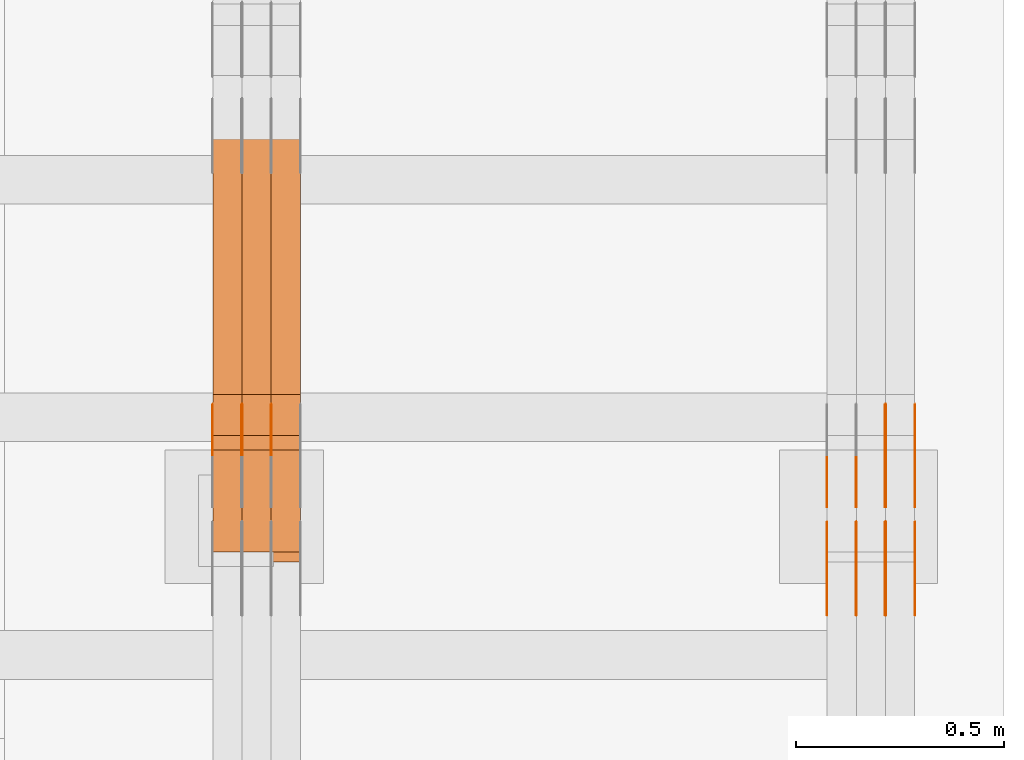
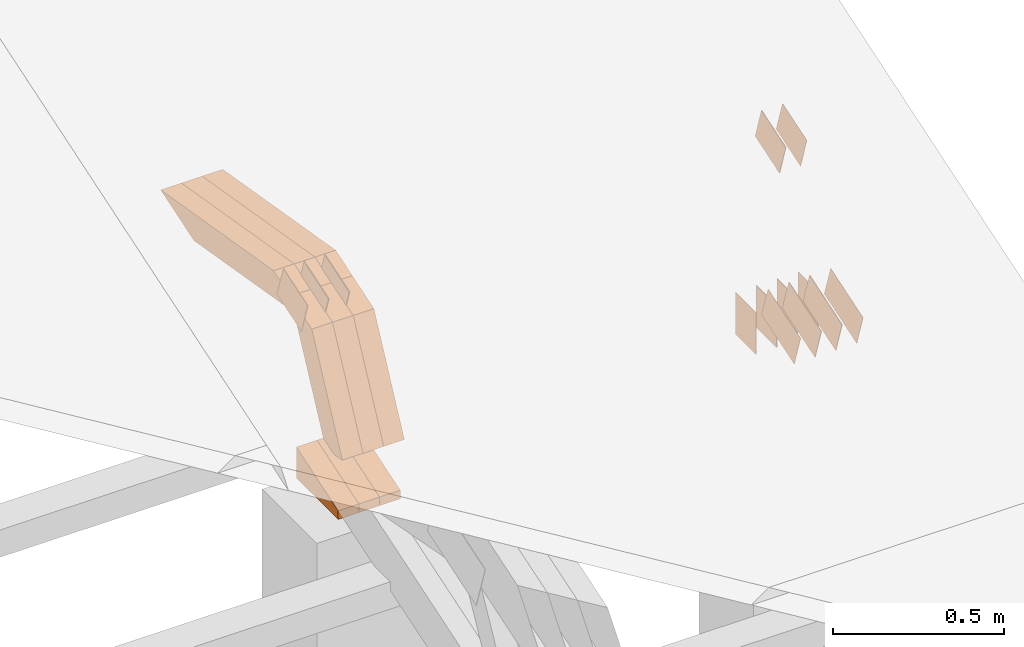
# One storey, part 321 of 385: 29 proxies.
"""IFC2X3 building model written with IfcOpenShell, lengths in millimetres."""

from ifc_helpers import new_model, entity, si_unit, converted_unit, derived_unit, direction, frame, frame_2d, origin, place, context, subcontext, project, spatial, polyline, rectangle, outline, extrude, source, transform, mapped, material, type_object, type_shapes, element, save


model = new_model("IFC2X3")

# Units and contexts
model_context = context("Model", 3, precision=0.01, world=origin(), true_north=direction((6.12303176911189e-17, 1.0)))
body_context = subcontext(model_context, "Body", "Model", "MODEL_VIEW")
ifc_project = project(units=[si_unit("LENGTHUNIT", "METRE", prefix="MILLI"), si_unit("AREAUNIT", "SQUARE_METRE"), si_unit("VOLUMEUNIT", "CUBIC_METRE"), converted_unit("PLANEANGLEUNIT", "DEGREE", entity("IfcRatioMeasure", 0.0174532925199433), si_unit("PLANEANGLEUNIT", "RADIAN"), dimensions=[0, 0, 0, 0, 0, 0, 0]), si_unit("MASSUNIT", "GRAM", prefix="KILO"), derived_unit("MASSDENSITYUNIT", [(si_unit("MASSUNIT", "GRAM", prefix="KILO"), 1), (si_unit("LENGTHUNIT", "METRE"), -3)]), si_unit("TIMEUNIT", "SECOND"), si_unit("FREQUENCYUNIT", "HERTZ"), si_unit("THERMODYNAMICTEMPERATUREUNIT", "DEGREE_CELSIUS"), derived_unit("THERMALTRANSMITTANCEUNIT", [(si_unit("MASSUNIT", "GRAM", prefix="KILO"), 1), (si_unit("THERMODYNAMICTEMPERATUREUNIT", "KELVIN"), -1), (si_unit("TIMEUNIT", "SECOND"), -3)]), derived_unit("VOLUMETRICFLOWRATEUNIT", [(si_unit("LENGTHUNIT", "METRE"), 3), (si_unit("TIMEUNIT", "SECOND"), -1)]), si_unit("ELECTRICCURRENTUNIT", "AMPERE"), si_unit("ELECTRICVOLTAGEUNIT", "VOLT"), si_unit("POWERUNIT", "WATT"), si_unit("FORCEUNIT", "NEWTON", prefix="KILO"), si_unit("ILLUMINANCEUNIT", "LUX"), si_unit("LUMINOUSFLUXUNIT", "LUMEN"), si_unit("LUMINOUSINTENSITYUNIT", "CANDELA"), derived_unit("USERDEFINED", [(si_unit("MASSUNIT", "GRAM", prefix="KILO"), -1), (si_unit("LENGTHUNIT", "METRE"), -2), (si_unit("TIMEUNIT", "SECOND"), 3), (si_unit("LUMINOUSFLUXUNIT", "LUMEN"), 1)]), derived_unit("LINEARVELOCITYUNIT", [(si_unit("LENGTHUNIT", "METRE"), 1), (si_unit("TIMEUNIT", "SECOND"), -1)]), si_unit("PRESSUREUNIT", "PASCAL"), derived_unit("USERDEFINED", [(si_unit("LENGTHUNIT", "METRE"), -2), (si_unit("MASSUNIT", "GRAM", prefix="KILO"), 1), (si_unit("TIMEUNIT", "SECOND"), -2)])], contexts=[model_context])

# Site, building, storey
site_placement = place(None, origin())
site = spatial("IfcSite", under=ifc_project, at=site_placement, CompositionType="ELEMENT")
building_placement = place(site_placement, origin())
building = spatial("IfcBuilding", under=site, at=building_placement, CompositionType="ELEMENT")
storey_placement = place(building_placement, origin())
storey = spatial("IfcBuildingStorey", under=building, at=storey_placement, Name="Default", CompositionType="ELEMENT", Elevation=0.0)

# Proxies
ifc_material_1 = material(Name="IfcSurfaceStyle #620272")
building_element_proxy_type_1 = type_object("IfcBuildingElementProxyType", PredefinedType="NOTDEFINED", material=ifc_material_1)
shared_shape_1 = source(origin(), body_context, "Body", "SweptSolid", [
    extrude(outline(polyline([(-99.9997874178038, -60.0000528641967), (99.9998102700997, -60.0000528641967), (99.9998251396068, 60.0000528641967), (-99.9998479919027, 60.0000528641967), (-99.9997874178038, -60.0000528641967)])), frame((99.9999918898597, 60.0000528641967, 0.0), z_axis=(0.0, 0.0, 1.0), x_axis=(-1.0, 0.0, 0.0)), (0.0, 0.0, 1.0), 1.3),
])
type_shapes(building_element_proxy_type_1, [shared_shape_1])
proxy_1_placement = place(building_placement, frame((49861.3, 11991.9568177725, 3072.52282247925), z_axis=(-1.0, 0.0, 0.0), x_axis=(0.0, 0.951056516295124, 0.309016994375039)))
element("IfcBuildingElementProxy", 1, at=proxy_1_placement, inside=storey, type_object=building_element_proxy_type_1, material=ifc_material_1, context=body_context, shape_type="MappedRepresentation", body=[
    mapped(shared_shape_1, transform((0.0, 0.0, 0.0), scale=1.0)),
])
ifc_material_2 = material(Name="IfcSurfaceStyle #620215")
building_element_proxy_type_2 = type_object("IfcBuildingElementProxyType", PredefinedType="NOTDEFINED", material=ifc_material_2)
shared_shape_2 = source(origin(), body_context, "Body", "SweptSolid", [
    extrude(outline(polyline([(-99.9997874178038, -60.0000528641967), (99.9998102700997, -60.0000528641967), (99.9998251396068, 60.0000528641967), (-99.9998479919027, 60.0000528641967), (-99.9997874178038, -60.0000528641967)])), frame((99.9999918898597, 60.0000528641967, 0.0), z_axis=(0.0, 0.0, 1.0), x_axis=(-1.0, 0.0, 0.0)), (0.0, 0.0, 1.0), 1.3),
])
type_shapes(building_element_proxy_type_2, [shared_shape_2])
proxy_2_placement = place(building_placement, frame((49790.0, 11991.9568177725, 3072.52282247925), z_axis=(-1.0, 0.0, 0.0), x_axis=(0.0, 0.951056516295124, 0.309016994375039)))
element("IfcBuildingElementProxy", 2, at=proxy_2_placement, inside=storey, type_object=building_element_proxy_type_2, material=ifc_material_2, context=body_context, shape_type="MappedRepresentation", body=[
    mapped(shared_shape_2, transform((0.0, 0.0, 0.0), scale=1.0)),
])
ifc_material_3 = material(Name="IfcSurfaceStyle #620158")
building_element_proxy_type_3 = type_object("IfcBuildingElementProxyType", PredefinedType="NOTDEFINED", material=ifc_material_3)
shared_shape_3 = source(origin(), body_context, "Body", "SweptSolid", [
    extrude(outline(polyline([(-99.9997874178038, -60.0000528641967), (99.9998102700997, -60.0000528641967), (99.9998251396068, 60.0000528641967), (-99.9998479919027, 60.0000528641967), (-99.9997874178038, -60.0000528641967)])), frame((99.9999918898597, 60.0000528641967, 0.0), z_axis=(0.0, 0.0, 1.0), x_axis=(-1.0, 0.0, 0.0)), (0.0, 0.0, 1.0), 1.3),
])
type_shapes(building_element_proxy_type_3, [shared_shape_3])
proxy_3_placement = place(building_placement, frame((49791.3, 11991.9568177725, 3072.52282247925), z_axis=(-1.0, 0.0, 0.0), x_axis=(0.0, 0.951056516295124, 0.309016994375039)))
element("IfcBuildingElementProxy", 3, at=proxy_3_placement, inside=storey, type_object=building_element_proxy_type_3, material=ifc_material_3, context=body_context, shape_type="MappedRepresentation", body=[
    mapped(shared_shape_3, transform((0.0, 0.0, 0.0), scale=1.0)),
])
ifc_material_4 = material(Name="IfcSurfaceStyle #620101")
building_element_proxy_type_4 = type_object("IfcBuildingElementProxyType", PredefinedType="NOTDEFINED", material=ifc_material_4)
shared_shape_4 = source(origin(), body_context, "Body", "SweptSolid", [
    extrude(outline(polyline([(-99.9997874178038, -60.0000528641967), (99.9998102700997, -60.0000528641967), (99.9998251396068, 60.0000528641967), (-99.9998479919027, 60.0000528641967), (-99.9997874178038, -60.0000528641967)])), frame((99.9999918898597, 60.0000528641967, 0.0), z_axis=(0.0, 0.0, 1.0), x_axis=(-1.0, 0.0, 0.0)), (0.0, 0.0, 1.0), 1.29999999999998),
])
type_shapes(building_element_proxy_type_4, [shared_shape_4])
proxy_4_placement = place(building_placement, frame((49720.0, 11991.9568177725, 3072.52282247925), z_axis=(-1.0, 0.0, 0.0), x_axis=(0.0, 0.951056516295124, 0.309016994375039)))
element("IfcBuildingElementProxy", 4, at=proxy_4_placement, inside=storey, type_object=building_element_proxy_type_4, material=ifc_material_4, context=body_context, shape_type="MappedRepresentation", body=[
    mapped(shared_shape_4, transform((0.0, 0.0, 0.0), scale=1.0)),
])
ifc_material_5 = material(Name="IfcSurfaceStyle #620044")
building_element_proxy_type_5 = type_object("IfcBuildingElementProxyType", PredefinedType="NOTDEFINED", material=ifc_material_5)
shared_shape_5 = source(origin(), body_context, "Body", "SweptSolid", [
    extrude(outline(polyline([(-99.9997874178038, -60.0000528641967), (99.9998102700997, -60.0000528641967), (99.9998251396068, 60.0000528641967), (-99.9998479919027, 60.0000528641967), (-99.9997874178038, -60.0000528641967)])), frame((99.9999918898597, 60.0000528641967, 0.0), z_axis=(0.0, 0.0, 1.0), x_axis=(-1.0, 0.0, 0.0)), (0.0, 0.0, 1.0), 1.29999999999998),
])
type_shapes(building_element_proxy_type_5, [shared_shape_5])
proxy_5_placement = place(building_placement, frame((49721.3, 11991.9568177725, 3072.52282247925), z_axis=(-1.0, 0.0, 0.0), x_axis=(0.0, 0.951056516295124, 0.309016994375039)))
element("IfcBuildingElementProxy", 5, at=proxy_5_placement, inside=storey, type_object=building_element_proxy_type_5, material=ifc_material_5, context=body_context, shape_type="MappedRepresentation", body=[
    mapped(shared_shape_5, transform((0.0, 0.0, 0.0), scale=1.0)),
])
ifc_material_6 = material(Name="IfcSurfaceStyle #619987")
building_element_proxy_type_6 = type_object("IfcBuildingElementProxyType", PredefinedType="NOTDEFINED", material=ifc_material_6)
shared_shape_6 = source(origin(), body_context, "Body", "SweptSolid", [
    extrude(outline(polyline([(-99.9997874178038, -60.0000528641967), (99.9998102700997, -60.0000528641967), (99.9998251396068, 60.0000528641967), (-99.9998479919027, 60.0000528641967), (-99.9997874178038, -60.0000528641967)])), frame((99.9999918898597, 60.0000528641967, 0.0), z_axis=(0.0, 0.0, 1.0), x_axis=(-1.0, 0.0, 0.0)), (0.0, 0.0, 1.0), 1.29999999999999),
])
type_shapes(building_element_proxy_type_6, [shared_shape_6])
proxy_6_placement = place(building_placement, frame((49650.0, 11991.9568177725, 3072.52282247925), z_axis=(-1.0, 0.0, 0.0), x_axis=(0.0, 0.951056516295124, 0.309016994375039)))
element("IfcBuildingElementProxy", 6, at=proxy_6_placement, inside=storey, type_object=building_element_proxy_type_6, material=ifc_material_6, context=body_context, shape_type="MappedRepresentation", body=[
    mapped(shared_shape_6, transform((0.0, 0.0, 0.0), scale=1.0)),
])
ifc_material_7 = material(Name="IfcSurfaceStyle #619930")
building_element_proxy_type_7 = type_object("IfcBuildingElementProxyType", PredefinedType="NOTDEFINED", material=ifc_material_7)
shared_shape_7 = source(origin(), body_context, "Body", "SweptSolid", [
    extrude(rectangle(XDim=150.0, YDim=119.999999999985, at=frame_2d((-7.105427357601e-15, 0.0), x_axis=(1.0, 0.0))), frame((75.0, 60.0, 0.0), z_axis=(0.0, 0.0, 1.0), x_axis=(-1.0, 0.0, 0.0)), (0.0, 0.0, 1.0), 1.3),
])
type_shapes(building_element_proxy_type_7, [shared_shape_7])
proxy_7_placement = place(building_placement, frame((49861.3, 12372.95703125, 3007.04687500001), z_axis=(-1.0, 0.0, 0.0), x_axis=(0.0, 0.0, -1.0)))
element("IfcBuildingElementProxy", 7, at=proxy_7_placement, inside=storey, type_object=building_element_proxy_type_7, material=ifc_material_7, context=body_context, shape_type="MappedRepresentation", body=[
    mapped(shared_shape_7, transform((0.0, 0.0, 0.0), scale=1.0)),
])
ifc_material_8 = material(Name="IfcSurfaceStyle #619873")
building_element_proxy_type_8 = type_object("IfcBuildingElementProxyType", PredefinedType="NOTDEFINED", material=ifc_material_8)
shared_shape_8 = source(origin(), body_context, "Body", "SweptSolid", [
    extrude(rectangle(XDim=150.0, YDim=119.999999999985, at=frame_2d((-7.105427357601e-15, 0.0), x_axis=(1.0, 0.0))), frame((75.0, 60.0, 0.0), z_axis=(0.0, 0.0, 1.0), x_axis=(-1.0, 0.0, 0.0)), (0.0, 0.0, 1.0), 1.3),
])
type_shapes(building_element_proxy_type_8, [shared_shape_8])
proxy_8_placement = place(building_placement, frame((49790.0, 12372.95703125, 3007.04687500001), z_axis=(-1.0, 0.0, 0.0), x_axis=(0.0, 0.0, -1.0)))
element("IfcBuildingElementProxy", 8, at=proxy_8_placement, inside=storey, type_object=building_element_proxy_type_8, material=ifc_material_8, context=body_context, shape_type="MappedRepresentation", body=[
    mapped(shared_shape_8, transform((0.0, 0.0, 0.0), scale=1.0)),
])
ifc_material_9 = material(Name="IfcSurfaceStyle #619816")
building_element_proxy_type_9 = type_object("IfcBuildingElementProxyType", PredefinedType="NOTDEFINED", material=ifc_material_9)
shared_shape_9 = source(origin(), body_context, "Body", "SweptSolid", [
    extrude(rectangle(XDim=150.0, YDim=119.999999999985, at=frame_2d((-7.105427357601e-15, 0.0), x_axis=(1.0, 0.0))), frame((75.0, 60.0, 0.0), z_axis=(0.0, 0.0, 1.0), x_axis=(-1.0, 0.0, 0.0)), (0.0, 0.0, 1.0), 1.3),
])
type_shapes(building_element_proxy_type_9, [shared_shape_9])
proxy_9_placement = place(building_placement, frame((49791.3, 12372.95703125, 3007.04687500001), z_axis=(-1.0, 0.0, 0.0), x_axis=(0.0, 0.0, -1.0)))
element("IfcBuildingElementProxy", 9, at=proxy_9_placement, inside=storey, type_object=building_element_proxy_type_9, material=ifc_material_9, context=body_context, shape_type="MappedRepresentation", body=[
    mapped(shared_shape_9, transform((0.0, 0.0, 0.0), scale=1.0)),
])
ifc_material_10 = material(Name="IfcSurfaceStyle #619759")
building_element_proxy_type_10 = type_object("IfcBuildingElementProxyType", PredefinedType="NOTDEFINED", material=ifc_material_10)
shared_shape_10 = source(origin(), body_context, "Body", "SweptSolid", [
    extrude(rectangle(XDim=150.0, YDim=119.999999999985, at=frame_2d((-7.105427357601e-15, 0.0), x_axis=(1.0, 0.0))), frame((75.0, 60.0, 0.0), z_axis=(0.0, 0.0, 1.0), x_axis=(-1.0, 0.0, 0.0)), (0.0, 0.0, 1.0), 1.29999999999999),
])
type_shapes(building_element_proxy_type_10, [shared_shape_10])
proxy_10_placement = place(building_placement, frame((49720.0, 12372.95703125, 3007.04687500001), z_axis=(-1.0, 0.0, 0.0), x_axis=(0.0, 0.0, -1.0)))
element("IfcBuildingElementProxy", 10, at=proxy_10_placement, inside=storey, type_object=building_element_proxy_type_10, material=ifc_material_10, context=body_context, shape_type="MappedRepresentation", body=[
    mapped(shared_shape_10, transform((0.0, 0.0, 0.0), scale=1.0)),
])
ifc_material_11 = material(Name="IfcSurfaceStyle #619702")
building_element_proxy_type_11 = type_object("IfcBuildingElementProxyType", PredefinedType="NOTDEFINED", material=ifc_material_11)
shared_shape_11 = source(origin(), body_context, "Body", "SweptSolid", [
    extrude(rectangle(XDim=150.0, YDim=119.999999999985, at=frame_2d((-7.105427357601e-15, 0.0), x_axis=(1.0, 0.0))), frame((75.0, 60.0, 0.0), z_axis=(0.0, 0.0, 1.0), x_axis=(-1.0, 0.0, 0.0)), (0.0, 0.0, 1.0), 1.29999999999999),
])
type_shapes(building_element_proxy_type_11, [shared_shape_11])
proxy_11_placement = place(building_placement, frame((49721.3, 12372.95703125, 3007.04687500001), z_axis=(-1.0, 0.0, 0.0), x_axis=(0.0, 0.0, -1.0)))
element("IfcBuildingElementProxy", 11, at=proxy_11_placement, inside=storey, type_object=building_element_proxy_type_11, material=ifc_material_11, context=body_context, shape_type="MappedRepresentation", body=[
    mapped(shared_shape_11, transform((0.0, 0.0, 0.0), scale=1.0)),
])
ifc_material_12 = material(Name="IfcSurfaceStyle #619645")
building_element_proxy_type_12 = type_object("IfcBuildingElementProxyType", PredefinedType="NOTDEFINED", material=ifc_material_12)
shared_shape_12 = source(origin(), body_context, "Body", "SweptSolid", [
    extrude(rectangle(XDim=150.0, YDim=119.999999999985, at=frame_2d((-7.105427357601e-15, 0.0), x_axis=(1.0, 0.0))), frame((75.0, 60.0, 0.0), z_axis=(0.0, 0.0, 1.0), x_axis=(-1.0, 0.0, 0.0)), (0.0, 0.0, 1.0), 1.29999999999999),
])
type_shapes(building_element_proxy_type_12, [shared_shape_12])
proxy_12_placement = place(building_placement, frame((49650.0, 12372.95703125, 3007.04687500001), z_axis=(-1.0, 0.0, 0.0), x_axis=(0.0, 0.0, -1.0)))
element("IfcBuildingElementProxy", 12, at=proxy_12_placement, inside=storey, type_object=building_element_proxy_type_12, material=ifc_material_12, context=body_context, shape_type="MappedRepresentation", body=[
    mapped(shared_shape_12, transform((0.0, 0.0, 0.0), scale=1.0)),
])
ifc_material_13 = material(Name="IfcSurfaceStyle #612748")
building_element_proxy_type_13 = type_object("IfcBuildingElementProxyType", PredefinedType="NOTDEFINED", material=ifc_material_13)
shared_shape_13 = source(origin(), body_context, "Body", "SweptSolid", [
    extrude(outline(polyline([(-74.9998754286244, -60.0000016373506), (74.9998605591063, -60.0000016373506), (74.9998754286244, 60.0000016373506), (-74.9998605591063, 60.0000016373506), (-74.9998754286244, -60.0000016373506)])), frame((74.9998754286244, 60.0000016373506, 0.0), z_axis=(0.0, 0.0, 1.0), x_axis=(-1.0, 0.0, 0.0)), (0.0, 0.0, 1.0), 1.3),
])
type_shapes(building_element_proxy_type_13, [shared_shape_13])
proxy_13_placement = place(building_placement, frame((49861.3, 12321.1620861463, 3506.17707344366), z_axis=(-1.0, 0.0, 0.0), x_axis=(0.0, 0.951056516295154, 0.309016994374948)))
element("IfcBuildingElementProxy", 13, at=proxy_13_placement, inside=storey, type_object=building_element_proxy_type_13, material=ifc_material_13, context=body_context, shape_type="MappedRepresentation", body=[
    mapped(shared_shape_13, transform((0.0, 0.0, 0.0), scale=1.0)),
])
ifc_material_14 = material(Name="IfcSurfaceStyle #612691")
building_element_proxy_type_14 = type_object("IfcBuildingElementProxyType", PredefinedType="NOTDEFINED", material=ifc_material_14)
shared_shape_14 = source(origin(), body_context, "Body", "SweptSolid", [
    extrude(outline(polyline([(-74.9998754286244, -60.0000016373506), (74.9998605591063, -60.0000016373506), (74.9998754286244, 60.0000016373506), (-74.9998605591063, 60.0000016373506), (-74.9998754286244, -60.0000016373506)])), frame((74.9998754286244, 60.0000016373506, 0.0), z_axis=(0.0, 0.0, 1.0), x_axis=(-1.0, 0.0, 0.0)), (0.0, 0.0, 1.0), 1.3),
])
type_shapes(building_element_proxy_type_14, [shared_shape_14])
proxy_14_placement = place(building_placement, frame((49790.0, 12321.1620861463, 3506.17707344366), z_axis=(-1.0, 0.0, 0.0), x_axis=(0.0, 0.951056516295154, 0.309016994374948)))
element("IfcBuildingElementProxy", 14, at=proxy_14_placement, inside=storey, type_object=building_element_proxy_type_14, material=ifc_material_14, context=body_context, shape_type="MappedRepresentation", body=[
    mapped(shared_shape_14, transform((0.0, 0.0, 0.0), scale=1.0)),
])
ifc_material_15 = material(Name="IfcSurfaceStyle #612634")
building_element_proxy_type_15 = type_object("IfcBuildingElementProxyType", PredefinedType="NOTDEFINED", material=ifc_material_15)
shared_shape_15 = source(origin(), body_context, "Body", "SweptSolid", [
    extrude(outline(polyline([(-74.9998754286244, -60.0000016373506), (74.9998605591063, -60.0000016373506), (74.9998754286244, 60.0000016373506), (-74.9998605591063, 60.0000016373506), (-74.9998754286244, -60.0000016373506)])), frame((74.9998754286244, 60.0000016373506, 0.0), z_axis=(0.0, 0.0, 1.0), x_axis=(-1.0, 0.0, 0.0)), (0.0, 0.0, 1.0), 1.3),
])
type_shapes(building_element_proxy_type_15, [shared_shape_15])
proxy_15_placement = place(building_placement, frame((49791.3, 12321.1620861463, 3506.17707344366), z_axis=(-1.0, 0.0, 0.0), x_axis=(0.0, 0.951056516295154, 0.309016994374948)))
element("IfcBuildingElementProxy", 15, at=proxy_15_placement, inside=storey, type_object=building_element_proxy_type_15, material=ifc_material_15, context=body_context, shape_type="MappedRepresentation", body=[
    mapped(shared_shape_15, transform((0.0, 0.0, 0.0), scale=1.0)),
])
ifc_material_16 = material(Name="IfcSurfaceStyle #578259")
building_element_proxy_type_16 = type_object("IfcBuildingElementProxyType", PredefinedType="NOTDEFINED", material=ifc_material_16)
shared_shape_16 = source(origin(), body_context, "Body", "SweptSolid", [
    extrude(outline(polyline([(-74.9998754286244, -60.0000016373506), (74.9998605591063, -60.0000016373506), (74.9998754286244, 60.0000016373506), (-74.9998605591063, 60.0000016373506), (-74.9998754286244, -60.0000016373506)])), frame((74.9998754286244, 60.0000016373506, 0.0), z_axis=(0.0, 0.0, 1.0), x_axis=(-1.0, 0.0, 0.0)), (0.0, 0.0, 1.0), 1.3),
])
type_shapes(building_element_proxy_type_16, [shared_shape_16])
proxy_16_placement = place(building_placement, frame((48315.0, 12321.1620861463, 3506.17707344366), z_axis=(-1.0, 0.0, 0.0), x_axis=(0.0, 0.951056516295154, 0.309016994374948)))
element("IfcBuildingElementProxy", 16, at=proxy_16_placement, inside=storey, type_object=building_element_proxy_type_16, material=ifc_material_16, context=body_context, shape_type="MappedRepresentation", body=[
    mapped(shared_shape_16, transform((0.0, 0.0, 0.0), scale=1.0)),
])
ifc_material_17 = material(Name="IfcSurfaceStyle #578202")
building_element_proxy_type_17 = type_object("IfcBuildingElementProxyType", PredefinedType="NOTDEFINED", material=ifc_material_17)
shared_shape_17 = source(origin(), body_context, "Body", "SweptSolid", [
    extrude(outline(polyline([(-74.9998754286244, -60.0000016373506), (74.9998605591063, -60.0000016373506), (74.9998754286244, 60.0000016373506), (-74.9998605591063, 60.0000016373506), (-74.9998754286244, -60.0000016373506)])), frame((74.9998754286244, 60.0000016373506, 0.0), z_axis=(0.0, 0.0, 1.0), x_axis=(-1.0, 0.0, 0.0)), (0.0, 0.0, 1.0), 1.3),
])
type_shapes(building_element_proxy_type_17, [shared_shape_17])
proxy_17_placement = place(building_placement, frame((48316.3, 12321.1620861463, 3506.17707344366), z_axis=(-1.0, 0.0, 0.0), x_axis=(0.0, 0.951056516295154, 0.309016994374948)))
element("IfcBuildingElementProxy", 17, at=proxy_17_placement, inside=storey, type_object=building_element_proxy_type_17, material=ifc_material_17, context=body_context, shape_type="MappedRepresentation", body=[
    mapped(shared_shape_17, transform((0.0, 0.0, 0.0), scale=1.0)),
])
ifc_material_18 = material(Name="IfcSurfaceStyle #578145")
building_element_proxy_type_18 = type_object("IfcBuildingElementProxyType", PredefinedType="NOTDEFINED", material=ifc_material_18)
shared_shape_18 = source(origin(), body_context, "Body", "SweptSolid", [
    extrude(outline(polyline([(-74.9998754286244, -60.0000016373506), (74.9998605591063, -60.0000016373506), (74.9998754286244, 60.0000016373506), (-74.9998605591063, 60.0000016373506), (-74.9998754286244, -60.0000016373506)])), frame((74.9998754286244, 60.0000016373506, 0.0), z_axis=(0.0, 0.0, 1.0), x_axis=(-1.0, 0.0, 0.0)), (0.0, 0.0, 1.0), 1.29999999999999),
])
type_shapes(building_element_proxy_type_18, [shared_shape_18])
proxy_18_placement = place(building_placement, frame((48245.0, 12321.1620861463, 3506.17707344366), z_axis=(-1.0, 0.0, 0.0), x_axis=(0.0, 0.951056516295154, 0.309016994374948)))
element("IfcBuildingElementProxy", 18, at=proxy_18_placement, inside=storey, type_object=building_element_proxy_type_18, material=ifc_material_18, context=body_context, shape_type="MappedRepresentation", body=[
    mapped(shared_shape_18, transform((0.0, 0.0, 0.0), scale=1.0)),
])
ifc_material_19 = material(Name="IfcSurfaceStyle #578088")
building_element_proxy_type_19 = type_object("IfcBuildingElementProxyType", PredefinedType="NOTDEFINED", material=ifc_material_19)
shared_shape_19 = source(origin(), body_context, "Body", "SweptSolid", [
    extrude(outline(polyline([(-74.9998754286244, -60.0000016373506), (74.9998605591063, -60.0000016373506), (74.9998754286244, 60.0000016373506), (-74.9998605591063, 60.0000016373506), (-74.9998754286244, -60.0000016373506)])), frame((74.9998754286244, 60.0000016373506, 0.0), z_axis=(0.0, 0.0, 1.0), x_axis=(-1.0, 0.0, 0.0)), (0.0, 0.0, 1.0), 1.29999999999999),
])
type_shapes(building_element_proxy_type_19, [shared_shape_19])
proxy_19_placement = place(building_placement, frame((48246.3, 12321.1620861463, 3506.17707344366), z_axis=(-1.0, 0.0, 0.0), x_axis=(0.0, 0.951056516295154, 0.309016994374948)))
element("IfcBuildingElementProxy", 19, at=proxy_19_placement, inside=storey, type_object=building_element_proxy_type_19, material=ifc_material_19, context=body_context, shape_type="MappedRepresentation", body=[
    mapped(shared_shape_19, transform((0.0, 0.0, 0.0), scale=1.0)),
])
ifc_material_20 = material(Name="IfcSurfaceStyle #578031")
building_element_proxy_type_20 = type_object("IfcBuildingElementProxyType", PredefinedType="NOTDEFINED", material=ifc_material_20)
shared_shape_20 = source(origin(), body_context, "Body", "SweptSolid", [
    extrude(outline(polyline([(-74.9998754286244, -60.0000016373506), (74.9998605591063, -60.0000016373506), (74.9998754286244, 60.0000016373506), (-74.9998605591063, 60.0000016373506), (-74.9998754286244, -60.0000016373506)])), frame((74.9998754286244, 60.0000016373506, 0.0), z_axis=(0.0, 0.0, 1.0), x_axis=(-1.0, 0.0, 0.0)), (0.0, 0.0, 1.0), 1.29999999999999),
])
type_shapes(building_element_proxy_type_20, [shared_shape_20])
proxy_20_placement = place(building_placement, frame((48175.0, 12321.1620861463, 3506.17707344366), z_axis=(-1.0, 0.0, 0.0), x_axis=(0.0, 0.951056516295154, 0.309016994374948)))
element("IfcBuildingElementProxy", 20, at=proxy_20_placement, inside=storey, type_object=building_element_proxy_type_20, material=ifc_material_20, context=body_context, shape_type="MappedRepresentation", body=[
    mapped(shared_shape_20, transform((0.0, 0.0, 0.0), scale=1.0)),
])
ifc_material_21 = material(Name="IfcSurfaceStyle #569856")
building_element_proxy_type_21 = type_object("IfcBuildingElementProxyType", Name="T1-E1 569854", PredefinedType="NOTDEFINED", material=ifc_material_21)
shared_shape_21 = source(origin(), body_context, "Body", "SweptSolid", [
    extrude(outline(polyline([(-75.1378173828004, -122.500000000005), (35.3350830078246, -122.500000000005), (35.3350830078004, 122.500000000005), (4.46765136717545, 122.500000000005), (-75.1378173828004, -122.500000000005)])), frame((35.3350830078246, 122.500000104877, 0.0), z_axis=(0.0, 0.0, 1.0), x_axis=(-1.0, 0.0, 0.0)), (0.0, 0.0, 1.0), 70.0),
])
type_shapes(building_element_proxy_type_21, [shared_shape_21])
proxy_21_placement = place(building_placement, frame((48385.0, 12145.0, 2849.54565429685), z_axis=(-1.0, 0.0, 0.0), x_axis=(0.0, 0.0, 1.0)))
element("IfcBuildingElementProxy", 21, at=proxy_21_placement, inside=storey, type_object=building_element_proxy_type_21, material=ifc_material_21, Name="T1-E1", context=body_context, shape_type="MappedRepresentation", body=[
    mapped(shared_shape_21, transform((0.0, 0.0, 0.0), scale=1.0)),
])
ifc_material_22 = material(Name="IfcSurfaceStyle #569799")
building_element_proxy_type_22 = type_object("IfcBuildingElementProxyType", Name="T1-E1 569797", PredefinedType="NOTDEFINED", material=ifc_material_22)
shared_shape_22 = source(origin(), body_context, "Body", "SweptSolid", [
    extrude(outline(polyline([(-75.1378173828004, -122.500000000005), (35.3350830078246, -122.500000000005), (35.3350830078004, 122.500000000005), (4.46765136717545, 122.500000000005), (-75.1378173828004, -122.500000000005)])), frame((35.3350830078246, 122.500000104877, 0.0), z_axis=(0.0, 0.0, 1.0), x_axis=(-1.0, 0.0, 0.0)), (0.0, 0.0, 1.0), 70.0),
])
type_shapes(building_element_proxy_type_22, [shared_shape_22])
proxy_22_placement = place(building_placement, frame((48315.0, 12145.0, 2849.54565429685), z_axis=(-1.0, 0.0, 0.0), x_axis=(0.0, 0.0, 1.0)))
element("IfcBuildingElementProxy", 22, at=proxy_22_placement, inside=storey, type_object=building_element_proxy_type_22, material=ifc_material_22, Name="T1-E1", context=body_context, shape_type="MappedRepresentation", body=[
    mapped(shared_shape_22, transform((0.0, 0.0, 0.0), scale=1.0)),
])
ifc_material_23 = material(Name="IfcSurfaceStyle #569742")
building_element_proxy_type_23 = type_object("IfcBuildingElementProxyType", Name="T1-E1 569740", PredefinedType="NOTDEFINED", material=ifc_material_23)
shared_shape_23 = source(origin(), body_context, "Body", "SweptSolid", [
    extrude(outline(polyline([(-75.1378173828004, -122.500000000005), (35.3350830078246, -122.500000000005), (35.3350830078004, 122.500000000005), (4.46765136717545, 122.500000000005), (-75.1378173828004, -122.500000000005)])), frame((35.3350830078246, 122.500000104877, 0.0), z_axis=(0.0, 0.0, 1.0), x_axis=(-1.0, 0.0, 0.0)), (0.0, 0.0, 1.0), 70.0),
])
type_shapes(building_element_proxy_type_23, [shared_shape_23])
proxy_23_placement = place(building_placement, frame((48245.0, 12145.0, 2849.54565429685), z_axis=(-1.0, 0.0, 0.0), x_axis=(0.0, 0.0, 1.0)))
element("IfcBuildingElementProxy", 23, at=proxy_23_placement, inside=storey, type_object=building_element_proxy_type_23, material=ifc_material_23, Name="T1-E1", context=body_context, shape_type="MappedRepresentation", body=[
    mapped(shared_shape_23, transform((0.0, 0.0, 0.0), scale=1.0)),
])
ifc_material_24 = material(Name="IfcSurfaceStyle #568128")
building_element_proxy_type_24 = type_object("IfcBuildingElementProxyType", Name="T1-W7 568126", PredefinedType="NOTDEFINED", material=ifc_material_24)
shared_shape_24 = source(origin(), body_context, "Body", "SweptSolid", [
    extrude(outline(polyline([(-296.174043820986, -47.5000676566704), (297.841254477443, -47.5000676566704), (283.518570346415, -7.10254316533821e-06), (192.674144473719, 47.500071207942), (-477.859925476591, 47.500071207942), (-296.174043820986, -47.5000676566704)])), frame((297.841254477443, 47.5000816097442, 0.0), z_axis=(0.0, 0.0, 1.0), x_axis=(-1.0, 0.0, 0.0)), (0.0, 0.0, 1.0), 70.0),
])
type_shapes(building_element_proxy_type_24, [shared_shape_24])
proxy_24_placement = place(building_placement, frame((48385.0, 12419.2991208897, 3526.2136755972), z_axis=(-1.0, 0.0, 0.0), x_axis=(0.0, 0.985983815111804, -0.166840991178939)))
element("IfcBuildingElementProxy", 24, at=proxy_24_placement, inside=storey, type_object=building_element_proxy_type_24, material=ifc_material_24, Name="T1-W7", context=body_context, shape_type="MappedRepresentation", body=[
    mapped(shared_shape_24, transform((0.0, 0.0, 0.0), scale=1.0)),
])
ifc_material_25 = material(Name="IfcSurfaceStyle #568062")
building_element_proxy_type_25 = type_object("IfcBuildingElementProxyType", Name="T1-W7 568060", PredefinedType="NOTDEFINED", material=ifc_material_25)
shared_shape_25 = source(origin(), body_context, "Body", "SweptSolid", [
    extrude(outline(polyline([(-296.174043820986, -47.5000676566704), (297.841254477443, -47.5000676566704), (283.518570346415, -7.10254316533821e-06), (192.674144473719, 47.500071207942), (-477.859925476591, 47.500071207942), (-296.174043820986, -47.5000676566704)])), frame((297.841254477443, 47.5000816097442, 0.0), z_axis=(0.0, 0.0, 1.0), x_axis=(-1.0, 0.0, 0.0)), (0.0, 0.0, 1.0), 70.0),
])
type_shapes(building_element_proxy_type_25, [shared_shape_25])
proxy_25_placement = place(building_placement, frame((48315.0, 12419.2991208897, 3526.2136755972), z_axis=(-1.0, 0.0, 0.0), x_axis=(0.0, 0.985983815111804, -0.166840991178939)))
element("IfcBuildingElementProxy", 25, at=proxy_25_placement, inside=storey, type_object=building_element_proxy_type_25, material=ifc_material_25, Name="T1-W7", context=body_context, shape_type="MappedRepresentation", body=[
    mapped(shared_shape_25, transform((0.0, 0.0, 0.0), scale=1.0)),
])
ifc_material_26 = material(Name="IfcSurfaceStyle #567996")
building_element_proxy_type_26 = type_object("IfcBuildingElementProxyType", Name="T1-W7 567994", PredefinedType="NOTDEFINED", material=ifc_material_26)
shared_shape_26 = source(origin(), body_context, "Body", "SweptSolid", [
    extrude(outline(polyline([(-296.174043820986, -47.5000676566704), (297.841254477443, -47.5000676566704), (283.518570346415, -7.10254316533821e-06), (192.674144473719, 47.500071207942), (-477.859925476591, 47.500071207942), (-296.174043820986, -47.5000676566704)])), frame((297.841254477443, 47.5000816097442, 0.0), z_axis=(0.0, 0.0, 1.0), x_axis=(-1.0, 0.0, 0.0)), (0.0, 0.0, 1.0), 70.0),
])
type_shapes(building_element_proxy_type_26, [shared_shape_26])
proxy_26_placement = place(building_placement, frame((48245.0, 12419.2991208897, 3526.2136755972), z_axis=(-1.0, 0.0, 0.0), x_axis=(0.0, 0.985983815111804, -0.166840991178939)))
element("IfcBuildingElementProxy", 26, at=proxy_26_placement, inside=storey, type_object=building_element_proxy_type_26, material=ifc_material_26, Name="T1-W7", context=body_context, shape_type="MappedRepresentation", body=[
    mapped(shared_shape_26, transform((0.0, 0.0, 0.0), scale=1.0)),
])
ifc_material_27 = material(Name="IfcSurfaceStyle #567732")
building_element_proxy_type_27 = type_object("IfcBuildingElementProxyType", Name="T1-W36 567730", PredefinedType="NOTDEFINED", material=ifc_material_27)
shared_shape_27 = source(origin(), body_context, "Body", "SweptSolid", [
    extrude(outline(polyline([(-300.714670922549, -47.4998881108849), (134.031527004269, -47.499888110885), (180.52054953879, -0.000136170977331764), (193.89900152221, 47.500563476126), (-207.736407142719, 47.4993489166213), (-300.714670922549, -47.4998881108849)])), frame((193.899145164686, 47.5001861375837, 0.0), z_axis=(0.0, 0.0, 1.0), x_axis=(-1.0, 3.02403492980632e-06, 0.0)), (0.0, 0.0, 1.0), 70.0),
])
type_shapes(building_element_proxy_type_27, [shared_shape_27])
proxy_27_placement = place(building_placement, frame((48385.0, 12120.5935627532, 3076.1128858536), z_axis=(-1.0, 0.0, 0.0), x_axis=(0.0, 0.444384650266842, 0.895836080210669)))
element("IfcBuildingElementProxy", 27, at=proxy_27_placement, inside=storey, type_object=building_element_proxy_type_27, material=ifc_material_27, Name="T1-W36", context=body_context, shape_type="MappedRepresentation", body=[
    mapped(shared_shape_27, transform((0.0, 0.0, 0.0), scale=1.0)),
])
ifc_material_28 = material(Name="IfcSurfaceStyle #567666")
building_element_proxy_type_28 = type_object("IfcBuildingElementProxyType", Name="T1-W36 567664", PredefinedType="NOTDEFINED", material=ifc_material_28)
shared_shape_28 = source(origin(), body_context, "Body", "SweptSolid", [
    extrude(outline(polyline([(-300.714670922549, -47.4998881108849), (134.031527004269, -47.499888110885), (180.52054953879, -0.000136170977331764), (193.89900152221, 47.500563476126), (-207.736407142719, 47.4993489166213), (-300.714670922549, -47.4998881108849)])), frame((193.899145164686, 47.5001861375837, 0.0), z_axis=(0.0, 0.0, 1.0), x_axis=(-1.0, 3.02403492980632e-06, 0.0)), (0.0, 0.0, 1.0), 70.0),
])
type_shapes(building_element_proxy_type_28, [shared_shape_28])
proxy_28_placement = place(building_placement, frame((48315.0, 12120.5935627532, 3076.1128858536), z_axis=(-1.0, 0.0, 0.0), x_axis=(0.0, 0.444384650266842, 0.895836080210669)))
element("IfcBuildingElementProxy", 28, at=proxy_28_placement, inside=storey, type_object=building_element_proxy_type_28, material=ifc_material_28, Name="T1-W36", context=body_context, shape_type="MappedRepresentation", body=[
    mapped(shared_shape_28, transform((0.0, 0.0, 0.0), scale=1.0)),
])
ifc_material_29 = material(Name="IfcSurfaceStyle #567600")
building_element_proxy_type_29 = type_object("IfcBuildingElementProxyType", Name="T1-W36 567598", PredefinedType="NOTDEFINED", material=ifc_material_29)
shared_shape_29 = source(origin(), body_context, "Body", "SweptSolid", [
    extrude(outline(polyline([(-300.714670922549, -47.4998881108849), (134.031527004269, -47.499888110885), (180.52054953879, -0.000136170977331764), (193.89900152221, 47.500563476126), (-207.736407142719, 47.4993489166213), (-300.714670922549, -47.4998881108849)])), frame((193.899145164686, 47.5001861375837, 0.0), z_axis=(0.0, 0.0, 1.0), x_axis=(-1.0, 3.02403492980632e-06, 0.0)), (0.0, 0.0, 1.0), 70.0),
])
type_shapes(building_element_proxy_type_29, [shared_shape_29])
proxy_29_placement = place(building_placement, frame((48245.0, 12120.5935627532, 3076.1128858536), z_axis=(-1.0, 0.0, 0.0), x_axis=(0.0, 0.444384650266842, 0.895836080210669)))
element("IfcBuildingElementProxy", 29, at=proxy_29_placement, inside=storey, type_object=building_element_proxy_type_29, material=ifc_material_29, Name="T1-W36", context=body_context, shape_type="MappedRepresentation", body=[
    mapped(shared_shape_29, transform((0.0, 0.0, 0.0), scale=1.0)),
])

save(model, "model.ifc")
